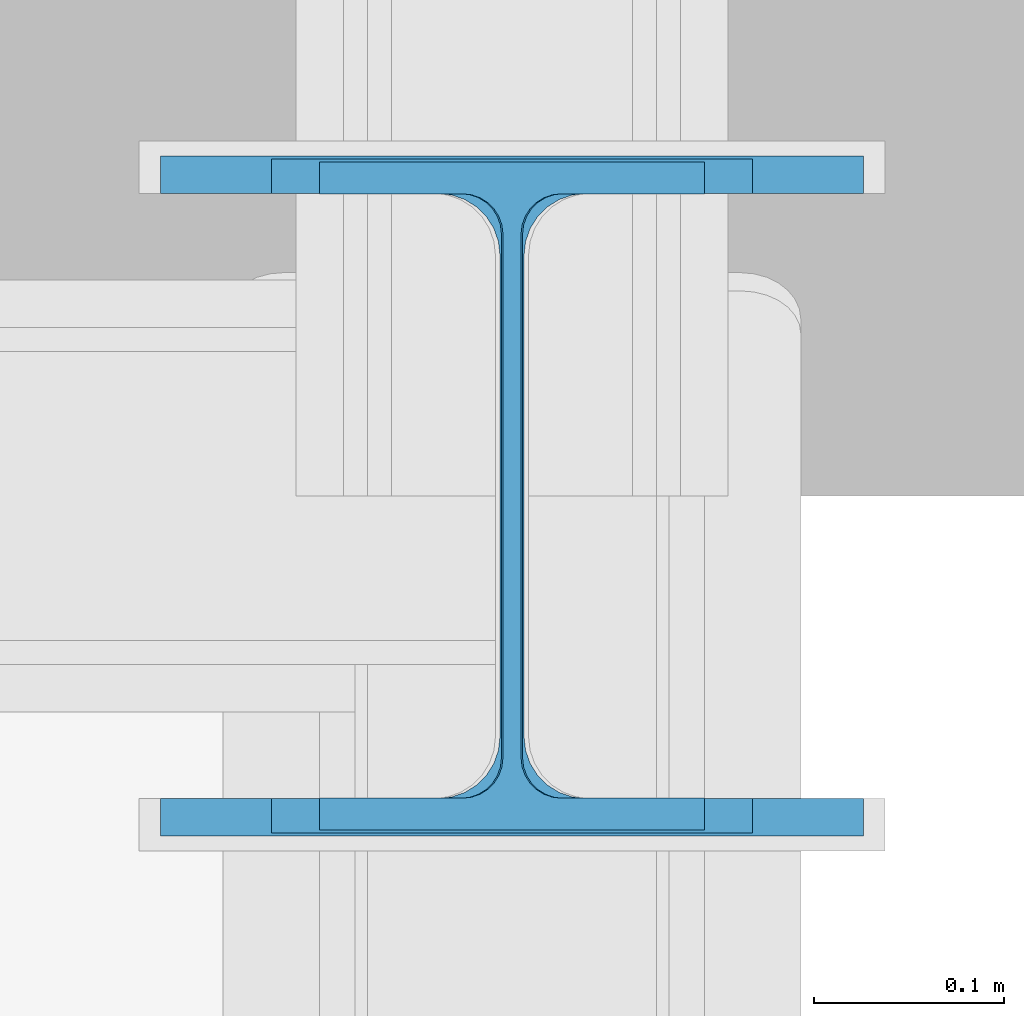
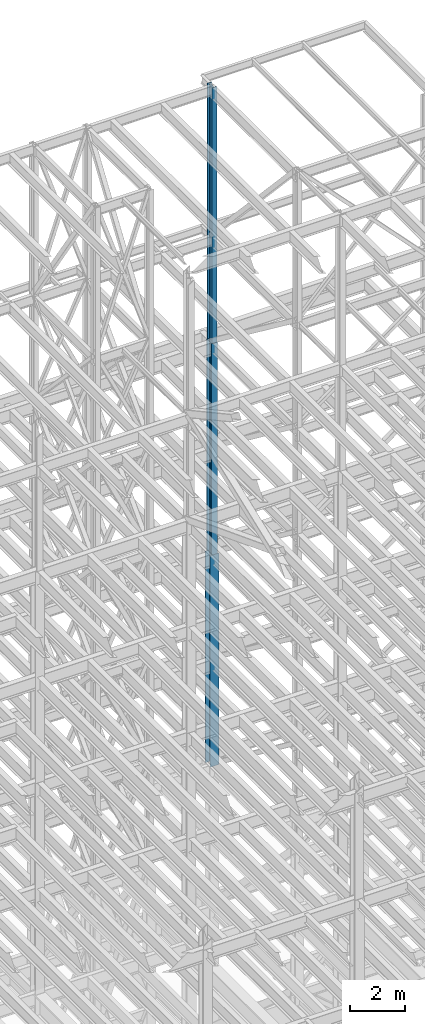
# One storey, part 116 of 150: 3 columns.
"""IFC2X3 building model written with IfcOpenShell, lengths in millimetres."""

from ifc_helpers import new_model, si_unit, frame, origin_with_axes, origin_2d_with_axis, place, context, subcontext, project, spatial, i_section, extrude, material, type_object, element, save


model = new_model("IFC2X3")

# Units and contexts
model_context = context("Model", 3, precision=1e-05, world=origin_with_axes())
body_context = subcontext(model_context, "Body", "Model", "MODEL_VIEW")
ifc_project = project(units=[si_unit("LENGTHUNIT", "METRE", prefix="MILLI"), si_unit("AREAUNIT", "SQUARE_METRE"), si_unit("VOLUMEUNIT", "CUBIC_METRE"), si_unit("MASSUNIT", "GRAM", prefix="KILO"), si_unit("TIMEUNIT", "SECOND"), si_unit("PLANEANGLEUNIT", "RADIAN"), si_unit("SOLIDANGLEUNIT", "STERADIAN"), si_unit("THERMODYNAMICTEMPERATUREUNIT", "DEGREE_CELSIUS"), si_unit("LUMINOUSINTENSITYUNIT", "LUMEN")], contexts=[model_context])

# Site, building, storey
site_placement = place(None, origin_with_axes())
site = spatial("IfcSite", under=ifc_project, at=site_placement, CompositionType="ELEMENT")
building_placement = place(site_placement, origin_with_axes())
building = spatial("IfcBuilding", under=site, at=building_placement, Name="Undefined", CompositionType="ELEMENT")
storey_placement = place(building_placement, origin_with_axes())
storey = spatial("IfcBuildingStorey", under=building, at=storey_placement, Name="Undefined", CompositionType="ELEMENT", Elevation=0.0)

# Columns
ifc_material = material(Name="STEEL/A992")
column_type_1 = type_object("IfcColumnType", Name="W14X53", PredefinedType="NOTDEFINED")
column_1_placement = place(storey_placement, frame((82194.4, 31877.0, 54483.0), z_axis=(0.0, 0.0, 1.0), x_axis=(1.0, 0.0, 0.0)))
element("IfcColumn", 1, at=column_1_placement, inside=storey, type_object=column_type_1, material=ifc_material, Name="COLUMN", ObjectType="W14X53", context=body_context, shape_type="SweptSolid", body=[
    extrude(i_section(OverallWidth=203.2, OverallDepth=352.425, WebThickness=9.5249, FlangeThickness=16.764, FilletRadius=21.336, at=origin_2d_with_axis()), frame((0.0, 0.0, 11430.0), z_axis=(0.0, 0.0, -1.0), x_axis=(-1.0, 0.0, 0.0)), (0.0, 0.0, 1.0), 11430.0),
])
column_type_2 = type_object("IfcColumnType", Name="W14X68", PredefinedType="NOTDEFINED")
column_2_placement = place(storey_placement, frame((82194.4, 31877.0, 45034.2), z_axis=(0.0, 0.0, 1.0), x_axis=(1.0, 0.0, 0.0)))
element("IfcColumn", 2, at=column_2_placement, inside=storey, type_object=column_type_2, material=ifc_material, Name="COLUMN", ObjectType="W14X68", context=body_context, shape_type="SweptSolid", body=[
    extrude(i_section(OverallWidth=254.0, OverallDepth=355.6, WebThickness=11.1125, FlangeThickness=18.288, FilletRadius=21.3994, at=origin_2d_with_axis()), frame((0.0, 0.0, 9448.8), z_axis=(0.0, 0.0, -1.0), x_axis=(-1.0, 0.0, 0.0)), (0.0, 0.0, 1.0), 9448.8),
])
column_type_3 = type_object("IfcColumnType", Name="W14X99", PredefinedType="NOTDEFINED")
column_3_placement = place(storey_placement, frame((82194.4, 31877.0, 35585.4), z_axis=(0.0, 0.0, 1.0), x_axis=(1.0, 0.0, 0.0)))
element("IfcColumn", 3, at=column_3_placement, inside=storey, type_object=column_type_3, material=ifc_material, Name="COLUMN", ObjectType="W14X99", context=body_context, shape_type="SweptSolid", body=[
    extrude(i_section(OverallWidth=370.84, OverallDepth=358.775, WebThickness=12.6999, FlangeThickness=19.812, FilletRadius=32.5755, at=origin_2d_with_axis()), frame((0.0, 0.0, 9448.8), z_axis=(0.0, 0.0, -1.0), x_axis=(-1.0, 0.0, 0.0)), (0.0, 0.0, 1.0), 9448.8),
])

save(model, "model.ifc")
